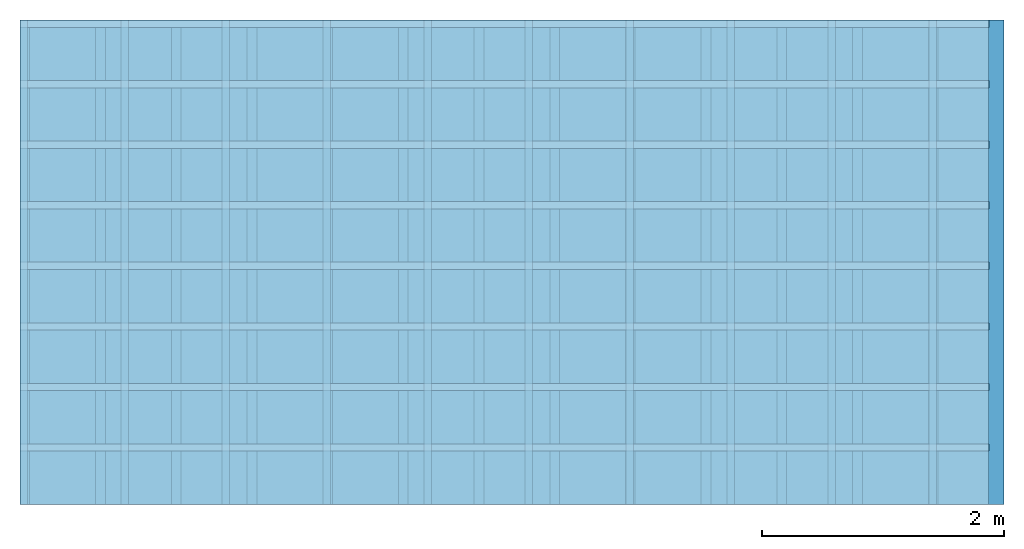
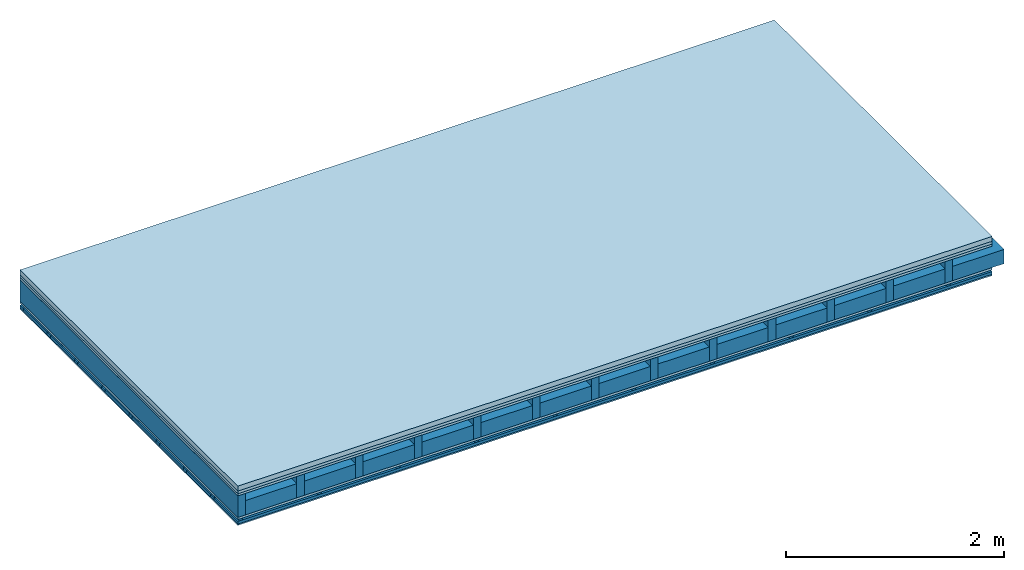
# One storey: 5 members, 5 plates, 1 element without a shape of its own.
"""IFC4 building model written with IfcOpenShell, lengths in metres."""

from ifc_helpers import new_model, si_unit, derived_unit, direction, frame, frame_2d, origin, origin_with_axes, place, context, project, spatial, polyline, rectangle, outline, extrude, material, layer, layer_set, type_object, element, aggregate, save


model = new_model("IFC4")

# Units and contexts
plan_context = context("Plan", 3, precision=1e-05, world=origin(), true_north=direction((0.0, 1.0)))
model_context = context("Model", 3, precision=1e-05, world=origin(), true_north=direction((0.0, 1.0)))
ifc_project = project(units=[si_unit("LENGTHUNIT", "METRE"), derived_unit("SOUNDPRESSUREUNIT", [(si_unit("PRESSUREUNIT", "PASCAL", prefix="MICRO"), 0)]), si_unit("ENERGYUNIT", "JOULE", prefix="MEGA"), si_unit("MASSUNIT", "GRAM", prefix="KILO"), derived_unit("THERMALTRANSMITTANCEUNIT", [(si_unit("POWERUNIT", "WATT"), 1), (si_unit("AREAUNIT", "SQUARE_METRE"), -1), (si_unit("THERMODYNAMICTEMPERATUREUNIT", "KELVIN"), -1)]), derived_unit("AREADENSITYUNIT", [(si_unit("MASSUNIT", "GRAM", prefix="KILO"), 1), (si_unit("AREAUNIT", "SQUARE_METRE"), -1)]), derived_unit("USERDEFINED", [(si_unit("ENERGYUNIT", "JOULE", prefix="MEGA"), 1), (si_unit("AREAUNIT", "SQUARE_METRE"), -1)])], contexts=[plan_context, model_context])

# Site, building, storey
site = spatial("IfcSite", under=ifc_project)
building_placement = place(None, origin())
building = spatial("IfcBuilding", under=site, at=building_placement)
storey_placement = place(building_placement, origin())
storey = spatial("IfcBuildingStorey", under=building, at=storey_placement)

# Slab, members, plates
ifc_material_1 = material(Category="04.005")
ifc_layer_1 = layer(ifc_material_1, 0.055, Name="On-material")
ifc_material_2 = material()
ifc_layer_2 = layer(ifc_material_2, 0.03, Name="Impact sound insulation")
ifc_material_3 = material(Category="07.001")
ifc_layer_3 = layer(ifc_material_3, 0.025, Name="Sub-floor")
ifc_material_4 = material(Name="Rigid, of the art")
ifc_layer_4 = layer(ifc_material_4, 0.0, Name="Bond")
ifc_layer_5 = layer(None, 0.24, Name="Supporting structure")
ifc_layer_6 = layer(ifc_material_4, 0.0, Name="Bond")
ifc_layer_7 = layer(ifc_material_3, 0.025, Name="Lower layer 1")
ifc_layer_8 = layer(None, 0.02, Name="Coupling")
ifc_layer_9 = layer(None, 0.03, Name="Battens / profiles")
ifc_material_5 = material(Category="03.007")
ifc_layer_10 = layer(ifc_material_5, 0.015, Name="Ceiling covering 1st layer")
ifc_material_6 = material(Name="Glued joints")
ifc_layer_11 = layer(ifc_material_6, 0.0, Name="Surface / treatment")
ifc_layer_set = layer_set([ifc_layer_1, ifc_layer_2, ifc_layer_3, ifc_layer_4, ifc_layer_5, ifc_layer_6, ifc_layer_7, ifc_layer_8, ifc_layer_9, ifc_layer_10, ifc_layer_11])
slab_type = type_object("IfcSlabType", Name="A0320", PredefinedType="NOTDEFINED", material=ifc_layer_set)
slab_placement = place(None, frame((0.0, 0.0, 0.0), z_axis=(0.0, 0.0, -1.0), x_axis=(1.0, 0.0, 0.0)))
slab = element("IfcSlab", 1, at=slab_placement, inside=storey, type_object=slab_type, material=ifc_layer_set, Name="Slab #1")
ifc_material_7 = material()
member_1_placement = place(slab_placement, origin())
member_1 = element("IfcMember", 2, at=member_1_placement, material=ifc_material_7, Name="Supporting structure", context=plan_context, shape_type="SweptSolid", body=[
    extrude(rectangle(XDim=0.08, YDim=0.24, at=frame_2d((0.04, 0.12), x_axis=(1.0, 0.0))), frame((0.0, 4.0, 0.11), z_axis=(0.0, -1.0, 0.0), x_axis=(1.0, 0.0, 0.0)), (0.0, 0.0, 1.0), 4.0),
    extrude(rectangle(XDim=0.08, YDim=0.24, at=frame_2d((0.04, 0.12), x_axis=(1.0, 0.0))), frame((0.625, 4.0, 0.11), z_axis=(0.0, -1.0, 0.0), x_axis=(1.0, 0.0, 0.0)), (0.0, 0.0, 1.0), 4.0),
    extrude(rectangle(XDim=0.08, YDim=0.24, at=frame_2d((0.04, 0.12), x_axis=(1.0, 0.0))), frame((1.25, 4.0, 0.11), z_axis=(0.0, -1.0, 0.0), x_axis=(1.0, 0.0, 0.0)), (0.0, 0.0, 1.0), 4.0),
    extrude(rectangle(XDim=0.08, YDim=0.24, at=frame_2d((0.04, 0.12), x_axis=(1.0, 0.0))), frame((1.875, 4.0, 0.11), z_axis=(0.0, -1.0, 0.0), x_axis=(1.0, 0.0, 0.0)), (0.0, 0.0, 1.0), 4.0),
    extrude(rectangle(XDim=0.08, YDim=0.24, at=frame_2d((0.04, 0.12), x_axis=(1.0, 0.0))), frame((2.5, 4.0, 0.11), z_axis=(0.0, -1.0, 0.0), x_axis=(1.0, 0.0, 0.0)), (0.0, 0.0, 1.0), 4.0),
    extrude(rectangle(XDim=0.08, YDim=0.24, at=frame_2d((0.04, 0.12), x_axis=(1.0, 0.0))), frame((3.125, 4.0, 0.11), z_axis=(0.0, -1.0, 0.0), x_axis=(1.0, 0.0, 0.0)), (0.0, 0.0, 1.0), 4.0),
    extrude(rectangle(XDim=0.08, YDim=0.24, at=frame_2d((0.04, 0.12), x_axis=(1.0, 0.0))), frame((3.75, 4.0, 0.11), z_axis=(0.0, -1.0, 0.0), x_axis=(1.0, 0.0, 0.0)), (0.0, 0.0, 1.0), 4.0),
    extrude(rectangle(XDim=0.08, YDim=0.24, at=frame_2d((0.04, 0.12), x_axis=(1.0, 0.0))), frame((4.375, 4.0, 0.11), z_axis=(0.0, -1.0, 0.0), x_axis=(1.0, 0.0, 0.0)), (0.0, 0.0, 1.0), 4.0),
    extrude(rectangle(XDim=0.08, YDim=0.24, at=frame_2d((0.04, 0.12), x_axis=(1.0, 0.0))), frame((5.0, 4.0, 0.11), z_axis=(0.0, -1.0, 0.0), x_axis=(1.0, 0.0, 0.0)), (0.0, 0.0, 1.0), 4.0),
    extrude(rectangle(XDim=0.08, YDim=0.24, at=frame_2d((0.04, 0.12), x_axis=(1.0, 0.0))), frame((5.625, 4.0, 0.11), z_axis=(0.0, -1.0, 0.0), x_axis=(1.0, 0.0, 0.0)), (0.0, 0.0, 1.0), 4.0),
    extrude(rectangle(XDim=0.08, YDim=0.24, at=frame_2d((0.04, 0.12), x_axis=(1.0, 0.0))), frame((6.25, 4.0, 0.11), z_axis=(0.0, -1.0, 0.0), x_axis=(1.0, 0.0, 0.0)), (0.0, 0.0, 1.0), 4.0),
    extrude(rectangle(XDim=0.08, YDim=0.24, at=frame_2d((0.04, 0.12), x_axis=(1.0, 0.0))), frame((6.875, 4.0, 0.11), z_axis=(0.0, -1.0, 0.0), x_axis=(1.0, 0.0, 0.0)), (0.0, 0.0, 1.0), 4.0),
    extrude(rectangle(XDim=0.08, YDim=0.24, at=frame_2d((0.04, 0.12), x_axis=(1.0, 0.0))), frame((7.5, 4.0, 0.11), z_axis=(0.0, -1.0, 0.0), x_axis=(1.0, 0.0, 0.0)), (0.0, 0.0, 1.0), 4.0),
])
ifc_material_8 = material()
member_2_placement = place(slab_placement, origin())
member_2 = element("IfcMember", 3, at=member_2_placement, material=ifc_material_8, Name="Cavity", context=plan_context, shape_type="SweptSolid", body=[
    extrude(rectangle(XDim=0.545, YDim=0.16, at=frame_2d((0.2725, 0.08), x_axis=(1.0, 0.0))), frame((0.08, 4.0, 0.19), z_axis=(0.0, -1.0, 0.0), x_axis=(1.0, 0.0, 0.0)), (0.0, 0.0, 1.0), 4.0),
    extrude(rectangle(XDim=0.545, YDim=0.16, at=frame_2d((0.2725, 0.08), x_axis=(1.0, 0.0))), frame((0.705, 4.0, 0.19), z_axis=(0.0, -1.0, 0.0), x_axis=(1.0, 0.0, 0.0)), (0.0, 0.0, 1.0), 4.0),
    extrude(rectangle(XDim=0.545, YDim=0.16, at=frame_2d((0.2725, 0.08), x_axis=(1.0, 0.0))), frame((1.33, 4.0, 0.19), z_axis=(0.0, -1.0, 0.0), x_axis=(1.0, 0.0, 0.0)), (0.0, 0.0, 1.0), 4.0),
    extrude(rectangle(XDim=0.545, YDim=0.16, at=frame_2d((0.2725, 0.08), x_axis=(1.0, 0.0))), frame((1.955, 4.0, 0.19), z_axis=(0.0, -1.0, 0.0), x_axis=(1.0, 0.0, 0.0)), (0.0, 0.0, 1.0), 4.0),
    extrude(rectangle(XDim=0.545, YDim=0.16, at=frame_2d((0.2725, 0.08), x_axis=(1.0, 0.0))), frame((2.58, 4.0, 0.19), z_axis=(0.0, -1.0, 0.0), x_axis=(1.0, 0.0, 0.0)), (0.0, 0.0, 1.0), 4.0),
    extrude(rectangle(XDim=0.545, YDim=0.16, at=frame_2d((0.2725, 0.08), x_axis=(1.0, 0.0))), frame((3.205, 4.0, 0.19), z_axis=(0.0, -1.0, 0.0), x_axis=(1.0, 0.0, 0.0)), (0.0, 0.0, 1.0), 4.0),
    extrude(rectangle(XDim=0.545, YDim=0.16, at=frame_2d((0.2725, 0.08), x_axis=(1.0, 0.0))), frame((3.83, 4.0, 0.19), z_axis=(0.0, -1.0, 0.0), x_axis=(1.0, 0.0, 0.0)), (0.0, 0.0, 1.0), 4.0),
    extrude(rectangle(XDim=0.545, YDim=0.16, at=frame_2d((0.2725, 0.08), x_axis=(1.0, 0.0))), frame((4.455, 4.0, 0.19), z_axis=(0.0, -1.0, 0.0), x_axis=(1.0, 0.0, 0.0)), (0.0, 0.0, 1.0), 4.0),
    extrude(rectangle(XDim=0.545, YDim=0.16, at=frame_2d((0.2725, 0.08), x_axis=(1.0, 0.0))), frame((5.08, 4.0, 0.19), z_axis=(0.0, -1.0, 0.0), x_axis=(1.0, 0.0, 0.0)), (0.0, 0.0, 1.0), 4.0),
    extrude(rectangle(XDim=0.545, YDim=0.16, at=frame_2d((0.2725, 0.08), x_axis=(1.0, 0.0))), frame((5.705, 4.0, 0.19), z_axis=(0.0, -1.0, 0.0), x_axis=(1.0, 0.0, 0.0)), (0.0, 0.0, 1.0), 4.0),
    extrude(rectangle(XDim=0.545, YDim=0.16, at=frame_2d((0.2725, 0.08), x_axis=(1.0, 0.0))), frame((6.33, 4.0, 0.19), z_axis=(0.0, -1.0, 0.0), x_axis=(1.0, 0.0, 0.0)), (0.0, 0.0, 1.0), 4.0),
    extrude(rectangle(XDim=0.545, YDim=0.16, at=frame_2d((0.2725, 0.08), x_axis=(1.0, 0.0))), frame((6.955, 4.0, 0.19), z_axis=(0.0, -1.0, 0.0), x_axis=(1.0, 0.0, 0.0)), (0.0, 0.0, 1.0), 4.0),
    extrude(rectangle(XDim=0.545, YDim=0.16, at=frame_2d((0.2725, 0.08), x_axis=(1.0, 0.0))), frame((7.58, 4.0, 0.19), z_axis=(0.0, -1.0, 0.0), x_axis=(1.0, 0.0, 0.0)), (0.0, 0.0, 1.0), 4.0),
])
ifc_material_9 = material()
member_3_placement = place(slab_placement, origin())
member_3 = element("IfcMember", 4, at=member_3_placement, material=ifc_material_9, Name="Coupling", context=plan_context, shape_type="SweptSolid", body=[
    extrude(outline(polyline([(0.0, 0.0), (0.06, 0.0), (0.04, 0.02), (0.02, 0.02), (0.0, 0.0)])), frame((0.0, 4.0, 0.375), z_axis=(0.0, -1.0, 0.0), x_axis=(1.0, 0.0, 0.0)), (0.0, 0.0, 1.0), 4.0),
    extrude(outline(polyline([(0.0, 0.0), (0.06, 0.0), (0.04, 0.02), (0.02, 0.02), (0.0, 0.0)])), frame((0.834, 4.0, 0.375), z_axis=(0.0, -1.0, 0.0), x_axis=(1.0, 0.0, 0.0)), (0.0, 0.0, 1.0), 4.0),
    extrude(outline(polyline([(0.0, 0.0), (0.06, 0.0), (0.04, 0.02), (0.02, 0.02), (0.0, 0.0)])), frame((1.668, 4.0, 0.375), z_axis=(0.0, -1.0, 0.0), x_axis=(1.0, 0.0, 0.0)), (0.0, 0.0, 1.0), 4.0),
    extrude(outline(polyline([(0.0, 0.0), (0.06, 0.0), (0.04, 0.02), (0.02, 0.02), (0.0, 0.0)])), frame((2.502, 4.0, 0.375), z_axis=(0.0, -1.0, 0.0), x_axis=(1.0, 0.0, 0.0)), (0.0, 0.0, 1.0), 4.0),
    extrude(outline(polyline([(0.0, 0.0), (0.06, 0.0), (0.04, 0.02), (0.02, 0.02), (0.0, 0.0)])), frame((3.336, 4.0, 0.375), z_axis=(0.0, -1.0, 0.0), x_axis=(1.0, 0.0, 0.0)), (0.0, 0.0, 1.0), 4.0),
    extrude(outline(polyline([(0.0, 0.0), (0.06, 0.0), (0.04, 0.02), (0.02, 0.02), (0.0, 0.0)])), frame((4.17, 4.0, 0.375), z_axis=(0.0, -1.0, 0.0), x_axis=(1.0, 0.0, 0.0)), (0.0, 0.0, 1.0), 4.0),
    extrude(outline(polyline([(0.0, 0.0), (0.06, 0.0), (0.04, 0.02), (0.02, 0.02), (0.0, 0.0)])), frame((5.004, 4.0, 0.375), z_axis=(0.0, -1.0, 0.0), x_axis=(1.0, 0.0, 0.0)), (0.0, 0.0, 1.0), 4.0),
    extrude(outline(polyline([(0.0, 0.0), (0.06, 0.0), (0.04, 0.02), (0.02, 0.02), (0.0, 0.0)])), frame((5.838, 4.0, 0.375), z_axis=(0.0, -1.0, 0.0), x_axis=(1.0, 0.0, 0.0)), (0.0, 0.0, 1.0), 4.0),
    extrude(outline(polyline([(0.0, 0.0), (0.06, 0.0), (0.04, 0.02), (0.02, 0.02), (0.0, 0.0)])), frame((6.672, 4.0, 0.375), z_axis=(0.0, -1.0, 0.0), x_axis=(1.0, 0.0, 0.0)), (0.0, 0.0, 1.0), 4.0),
    extrude(outline(polyline([(0.0, 0.0), (0.06, 0.0), (0.04, 0.02), (0.02, 0.02), (0.0, 0.0)])), frame((7.506, 4.0, 0.375), z_axis=(0.0, -1.0, 0.0), x_axis=(1.0, 0.0, 0.0)), (0.0, 0.0, 1.0), 4.0),
])
ifc_material_10 = material()
member_4_placement = place(slab_placement, origin())
member_4 = element("IfcMember", 5, at=member_4_placement, material=ifc_material_10, Name="Battens / profiles", context=plan_context, shape_type="SweptSolid", body=[
    extrude(rectangle(XDim=0.06, YDim=0.03, at=frame_2d((0.03, 0.015), x_axis=(1.0, 0.0))), frame((0.0, 0.0, 0.395), z_axis=(1.0, 0.0, 0.0), x_axis=(0.0, 1.0, 0.0)), (0.0, 0.0, 1.0), 8.0),
    extrude(rectangle(XDim=0.06, YDim=0.03, at=frame_2d((0.03, 0.015), x_axis=(1.0, 0.0))), frame((0.0, 0.5, 0.395), z_axis=(1.0, 0.0, 0.0), x_axis=(0.0, 1.0, 0.0)), (0.0, 0.0, 1.0), 8.0),
    extrude(rectangle(XDim=0.06, YDim=0.03, at=frame_2d((0.03, 0.015), x_axis=(1.0, 0.0))), frame((0.0, 1.0, 0.395), z_axis=(1.0, 0.0, 0.0), x_axis=(0.0, 1.0, 0.0)), (0.0, 0.0, 1.0), 8.0),
    extrude(rectangle(XDim=0.06, YDim=0.03, at=frame_2d((0.03, 0.015), x_axis=(1.0, 0.0))), frame((0.0, 1.5, 0.395), z_axis=(1.0, 0.0, 0.0), x_axis=(0.0, 1.0, 0.0)), (0.0, 0.0, 1.0), 8.0),
    extrude(rectangle(XDim=0.06, YDim=0.03, at=frame_2d((0.03, 0.015), x_axis=(1.0, 0.0))), frame((0.0, 2.0, 0.395), z_axis=(1.0, 0.0, 0.0), x_axis=(0.0, 1.0, 0.0)), (0.0, 0.0, 1.0), 8.0),
    extrude(rectangle(XDim=0.06, YDim=0.03, at=frame_2d((0.03, 0.015), x_axis=(1.0, 0.0))), frame((0.0, 2.5, 0.395), z_axis=(1.0, 0.0, 0.0), x_axis=(0.0, 1.0, 0.0)), (0.0, 0.0, 1.0), 8.0),
    extrude(rectangle(XDim=0.06, YDim=0.03, at=frame_2d((0.03, 0.015), x_axis=(1.0, 0.0))), frame((0.0, 3.0, 0.395), z_axis=(1.0, 0.0, 0.0), x_axis=(0.0, 1.0, 0.0)), (0.0, 0.0, 1.0), 8.0),
    extrude(rectangle(XDim=0.06, YDim=0.03, at=frame_2d((0.03, 0.015), x_axis=(1.0, 0.0))), frame((0.0, 3.5, 0.395), z_axis=(1.0, 0.0, 0.0), x_axis=(0.0, 1.0, 0.0)), (0.0, 0.0, 1.0), 8.0),
])
member_5_placement = place(slab_placement, origin())
member_5 = element("IfcMember", 6, at=member_5_placement, material=ifc_material_8, Name="Cavity", context=plan_context, shape_type="SweptSolid", body=[
    extrude(rectangle(XDim=0.44, YDim=0.03, at=frame_2d((0.22, 0.015), x_axis=(1.0, 0.0))), frame((0.0, 0.06, 0.395), z_axis=(1.0, 0.0, 0.0), x_axis=(0.0, 1.0, 0.0)), (0.0, 0.0, 1.0), 8.0),
    extrude(rectangle(XDim=0.44, YDim=0.03, at=frame_2d((0.22, 0.015), x_axis=(1.0, 0.0))), frame((0.0, 0.56, 0.395), z_axis=(1.0, 0.0, 0.0), x_axis=(0.0, 1.0, 0.0)), (0.0, 0.0, 1.0), 8.0),
    extrude(rectangle(XDim=0.44, YDim=0.03, at=frame_2d((0.22, 0.015), x_axis=(1.0, 0.0))), frame((0.0, 1.06, 0.395), z_axis=(1.0, 0.0, 0.0), x_axis=(0.0, 1.0, 0.0)), (0.0, 0.0, 1.0), 8.0),
    extrude(rectangle(XDim=0.44, YDim=0.03, at=frame_2d((0.22, 0.015), x_axis=(1.0, 0.0))), frame((0.0, 1.56, 0.395), z_axis=(1.0, 0.0, 0.0), x_axis=(0.0, 1.0, 0.0)), (0.0, 0.0, 1.0), 8.0),
    extrude(rectangle(XDim=0.44, YDim=0.03, at=frame_2d((0.22, 0.015), x_axis=(1.0, 0.0))), frame((0.0, 2.06, 0.395), z_axis=(1.0, 0.0, 0.0), x_axis=(0.0, 1.0, 0.0)), (0.0, 0.0, 1.0), 8.0),
    extrude(rectangle(XDim=0.44, YDim=0.03, at=frame_2d((0.22, 0.015), x_axis=(1.0, 0.0))), frame((0.0, 2.56, 0.395), z_axis=(1.0, 0.0, 0.0), x_axis=(0.0, 1.0, 0.0)), (0.0, 0.0, 1.0), 8.0),
    extrude(rectangle(XDim=0.44, YDim=0.03, at=frame_2d((0.22, 0.015), x_axis=(1.0, 0.0))), frame((0.0, 3.06, 0.395), z_axis=(1.0, 0.0, 0.0), x_axis=(0.0, 1.0, 0.0)), (0.0, 0.0, 1.0), 8.0),
    extrude(rectangle(XDim=0.44, YDim=0.03, at=frame_2d((0.22, 0.015), x_axis=(1.0, 0.0))), frame((0.0, 3.56, 0.395), z_axis=(1.0, 0.0, 0.0), x_axis=(0.0, 1.0, 0.0)), (0.0, 0.0, 1.0), 8.0),
])
plate_1_placement = place(slab_placement, origin())
plate_1 = element("IfcPlate", 7, at=plate_1_placement, material=ifc_material_1, Name="On-material", context=plan_context, shape_type="SweptSolid", body=[
    extrude(rectangle(XDim=8.0, YDim=4.0, at=frame_2d((4.0, 2.0), x_axis=(1.0, 0.0))), origin_with_axes(), (0.0, 0.0, 1.0), 0.055),
])
plate_2_placement = place(slab_placement, origin())
plate_2 = element("IfcPlate", 8, at=plate_2_placement, material=ifc_material_2, Name="Impact sound insulation", context=plan_context, shape_type="SweptSolid", body=[
    extrude(rectangle(XDim=8.0, YDim=4.0, at=frame_2d((4.0, 2.0), x_axis=(1.0, 0.0))), frame((0.0, 0.0, 0.055), z_axis=(0.0, 0.0, 1.0), x_axis=(1.0, 0.0, 0.0)), (0.0, 0.0, 1.0), 0.03),
])
plate_3_placement = place(slab_placement, origin())
plate_3 = element("IfcPlate", 9, at=plate_3_placement, material=ifc_material_3, Name="Sub-floor", context=plan_context, shape_type="SweptSolid", body=[
    extrude(rectangle(XDim=8.0, YDim=4.0, at=frame_2d((4.0, 2.0), x_axis=(1.0, 0.0))), frame((0.0, 0.0, 0.085), z_axis=(0.0, 0.0, 1.0), x_axis=(1.0, 0.0, 0.0)), (0.0, 0.0, 1.0), 0.025),
])
plate_4_placement = place(slab_placement, origin())
plate_4 = element("IfcPlate", 10, at=plate_4_placement, material=ifc_material_3, Name="Lower layer 1", context=plan_context, shape_type="SweptSolid", body=[
    extrude(rectangle(XDim=8.0, YDim=4.0, at=frame_2d((4.0, 2.0), x_axis=(1.0, 0.0))), frame((0.0, 0.0, 0.35), z_axis=(0.0, 0.0, 1.0), x_axis=(1.0, 0.0, 0.0)), (0.0, 0.0, 1.0), 0.025),
])
plate_5_placement = place(slab_placement, origin())
plate_5 = element("IfcPlate", 11, at=plate_5_placement, material=ifc_material_5, Name="Ceiling covering 1st layer", context=plan_context, shape_type="SweptSolid", body=[
    extrude(rectangle(XDim=8.0, YDim=4.0, at=frame_2d((4.0, 2.0), x_axis=(1.0, 0.0))), frame((0.0, 0.0, 0.425), z_axis=(0.0, 0.0, 1.0), x_axis=(1.0, 0.0, 0.0)), (0.0, 0.0, 1.0), 0.015),
])
aggregate(slab, [plate_1, plate_2, plate_3, member_1, member_2, plate_4, member_3, member_4, member_5, plate_5])

save(model, "model.ifc")
